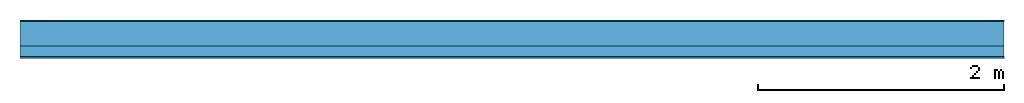
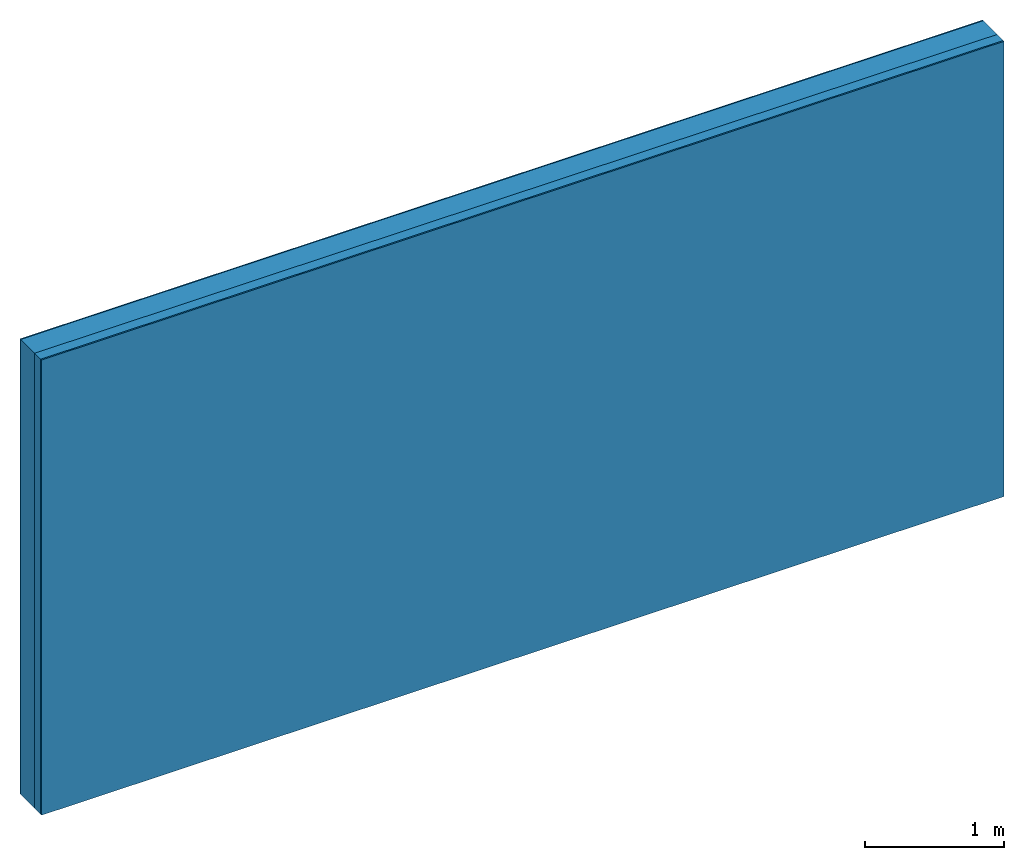
# One storey: 3 plates, 1 member, 1 element without a shape of its own.
"""IFC4 building model written with IfcOpenShell, lengths in metres."""

from ifc_helpers import new_model, si_unit, derived_unit, direction, frame, frame_2d, origin, origin_with_axes, place, context, project, spatial, rectangle, extrude, material, layer, layer_set, type_object, element, aggregate, save


model = new_model("IFC4")

# Units and contexts
plan_context = context("Plan", 3, precision=1e-05, world=origin(), true_north=direction((0.0, 1.0)))
model_context = context("Model", 3, precision=1e-05, world=origin(), true_north=direction((0.0, 1.0)))
ifc_project = project(units=[si_unit("LENGTHUNIT", "METRE"), derived_unit("SOUNDPRESSUREUNIT", [(si_unit("PRESSUREUNIT", "PASCAL", prefix="MICRO"), 0)]), si_unit("ENERGYUNIT", "JOULE", prefix="MEGA"), si_unit("MASSUNIT", "GRAM", prefix="KILO"), derived_unit("THERMALTRANSMITTANCEUNIT", [(si_unit("POWERUNIT", "WATT"), 1), (si_unit("AREAUNIT", "SQUARE_METRE"), -1), (si_unit("THERMODYNAMICTEMPERATUREUNIT", "KELVIN"), -1)]), derived_unit("AREADENSITYUNIT", [(si_unit("MASSUNIT", "GRAM", prefix="KILO"), 1), (si_unit("AREAUNIT", "SQUARE_METRE"), -1)]), derived_unit("USERDEFINED", [(si_unit("ENERGYUNIT", "JOULE", prefix="MEGA"), 1), (si_unit("AREAUNIT", "SQUARE_METRE"), -1)])], contexts=[plan_context, model_context])

# Site, building, storey
site = spatial("IfcSite", under=ifc_project)
building_placement = place(None, origin())
building = spatial("IfcBuilding", under=site, at=building_placement)
storey_placement = place(building_placement, origin())
storey = spatial("IfcBuildingStorey", under=building, at=storey_placement)

# Wall, member, plates
ifc_material_1 = material(Category="04.011")
ifc_layer_1 = layer(ifc_material_1, 0.01, Name="Surface 1")
ifc_material_2 = material(Name="Mineral wool", Category="10.008")
ifc_layer_2 = layer(ifc_material_2, 0.2, Name="outside 1st layer")
ifc_material_3 = material(Name="of the art")
ifc_layer_3 = layer(ifc_material_3, 0.0, Name="Bond")
ifc_layer_4 = layer(None, 0.087, Name="Support")
ifc_layer_5 = layer(ifc_material_3, 0.0, Name="Bond")
ifc_material_4 = material(Name="Plasterboard type A", Category="03.008")
ifc_layer_6 = layer(ifc_material_4, 0.0125, Name="1st layer")
ifc_material_5 = material(Name="joints", Category="04.017")
ifc_layer_7 = layer(ifc_material_5, 0.0, Name="Surface")
ifc_layer_set = layer_set([ifc_layer_1, ifc_layer_2, ifc_layer_3, ifc_layer_4, ifc_layer_5, ifc_layer_6, ifc_layer_7])
wall_type = type_object("IfcWallType", Name="D1021", PredefinedType="NOTDEFINED", material=ifc_layer_set)
wall_placement = place(None, frame((0.0, 0.0, 0.0), z_axis=(0.0, -1.0, 0.0), x_axis=(1.0, 0.0, 0.0)))
wall = element("IfcWall", 1, at=wall_placement, inside=storey, type_object=wall_type, material=ifc_layer_set, Name="Wall #1")
ifc_material_6 = material(Name="Solid timber panel")
member_placement = place(wall_placement, origin())
member = element("IfcMember", 2, at=member_placement, material=ifc_material_6, Name="Support", context=plan_context, shape_type="SweptSolid", body=[
    extrude(rectangle(XDim=1.0, YDim=0.087, at=frame_2d((0.5, 0.0435), x_axis=(1.0, 0.0))), frame((0.0, 4.0, 0.21), z_axis=(0.0, -1.0, 0.0), x_axis=(1.0, 0.0, 0.0)), (0.0, 0.0, 1.0), 4.0),
    extrude(rectangle(XDim=1.0, YDim=0.087, at=frame_2d((0.5, 0.0435), x_axis=(1.0, 0.0))), frame((1.0, 4.0, 0.21), z_axis=(0.0, -1.0, 0.0), x_axis=(1.0, 0.0, 0.0)), (0.0, 0.0, 1.0), 4.0),
    extrude(rectangle(XDim=1.0, YDim=0.087, at=frame_2d((0.5, 0.0435), x_axis=(1.0, 0.0))), frame((2.0, 4.0, 0.21), z_axis=(0.0, -1.0, 0.0), x_axis=(1.0, 0.0, 0.0)), (0.0, 0.0, 1.0), 4.0),
    extrude(rectangle(XDim=1.0, YDim=0.087, at=frame_2d((0.5, 0.0435), x_axis=(1.0, 0.0))), frame((3.0, 4.0, 0.21), z_axis=(0.0, -1.0, 0.0), x_axis=(1.0, 0.0, 0.0)), (0.0, 0.0, 1.0), 4.0),
    extrude(rectangle(XDim=1.0, YDim=0.087, at=frame_2d((0.5, 0.0435), x_axis=(1.0, 0.0))), frame((4.0, 4.0, 0.21), z_axis=(0.0, -1.0, 0.0), x_axis=(1.0, 0.0, 0.0)), (0.0, 0.0, 1.0), 4.0),
    extrude(rectangle(XDim=1.0, YDim=0.087, at=frame_2d((0.5, 0.0435), x_axis=(1.0, 0.0))), frame((5.0, 4.0, 0.21), z_axis=(0.0, -1.0, 0.0), x_axis=(1.0, 0.0, 0.0)), (0.0, 0.0, 1.0), 4.0),
    extrude(rectangle(XDim=1.0, YDim=0.087, at=frame_2d((0.5, 0.0435), x_axis=(1.0, 0.0))), frame((6.0, 4.0, 0.21), z_axis=(0.0, -1.0, 0.0), x_axis=(1.0, 0.0, 0.0)), (0.0, 0.0, 1.0), 4.0),
    extrude(rectangle(XDim=1.0, YDim=0.087, at=frame_2d((0.5, 0.0435), x_axis=(1.0, 0.0))), frame((7.0, 4.0, 0.21), z_axis=(0.0, -1.0, 0.0), x_axis=(1.0, 0.0, 0.0)), (0.0, 0.0, 1.0), 4.0),
])
plate_1_placement = place(wall_placement, origin())
plate_1 = element("IfcPlate", 3, at=plate_1_placement, material=ifc_material_1, Name="Surface 1", context=plan_context, shape_type="SweptSolid", body=[
    extrude(rectangle(XDim=8.0, YDim=4.0, at=frame_2d((4.0, 2.0), x_axis=(1.0, 0.0))), origin_with_axes(), (0.0, 0.0, 1.0), 0.01),
])
plate_2_placement = place(wall_placement, origin())
plate_2 = element("IfcPlate", 4, at=plate_2_placement, material=ifc_material_2, Name="outside 1st layer", context=plan_context, shape_type="SweptSolid", body=[
    extrude(rectangle(XDim=8.0, YDim=4.0, at=frame_2d((4.0, 2.0), x_axis=(1.0, 0.0))), frame((0.0, 0.0, 0.01), z_axis=(0.0, 0.0, 1.0), x_axis=(1.0, 0.0, 0.0)), (0.0, 0.0, 1.0), 0.2),
])
plate_3_placement = place(wall_placement, origin())
plate_3 = element("IfcPlate", 5, at=plate_3_placement, material=ifc_material_4, Name="1st layer", context=plan_context, shape_type="SweptSolid", body=[
    extrude(rectangle(XDim=8.0, YDim=4.0, at=frame_2d((4.0, 2.0), x_axis=(1.0, 0.0))), frame((0.0, 0.0, 0.297), z_axis=(0.0, 0.0, 1.0), x_axis=(1.0, 0.0, 0.0)), (0.0, 0.0, 1.0), 0.0125),
])
aggregate(wall, [plate_1, plate_2, member, plate_3])

save(model, "model.ifc")
